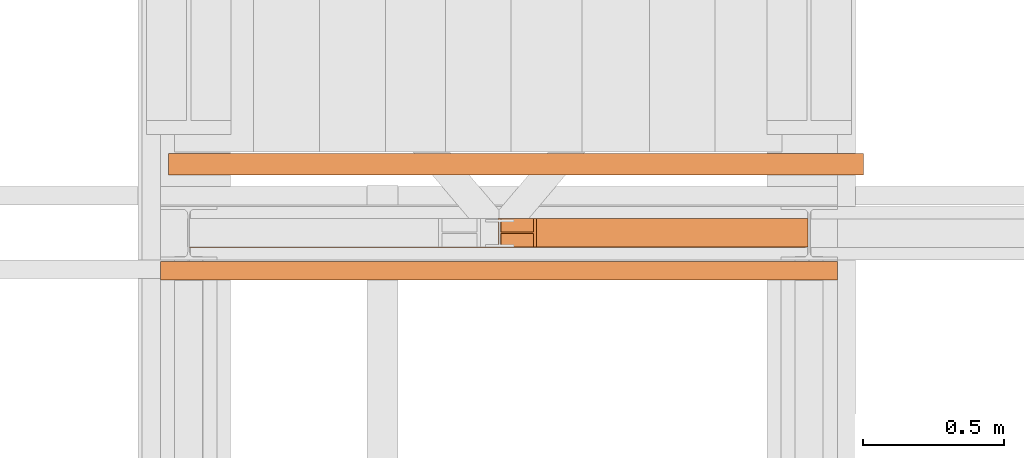
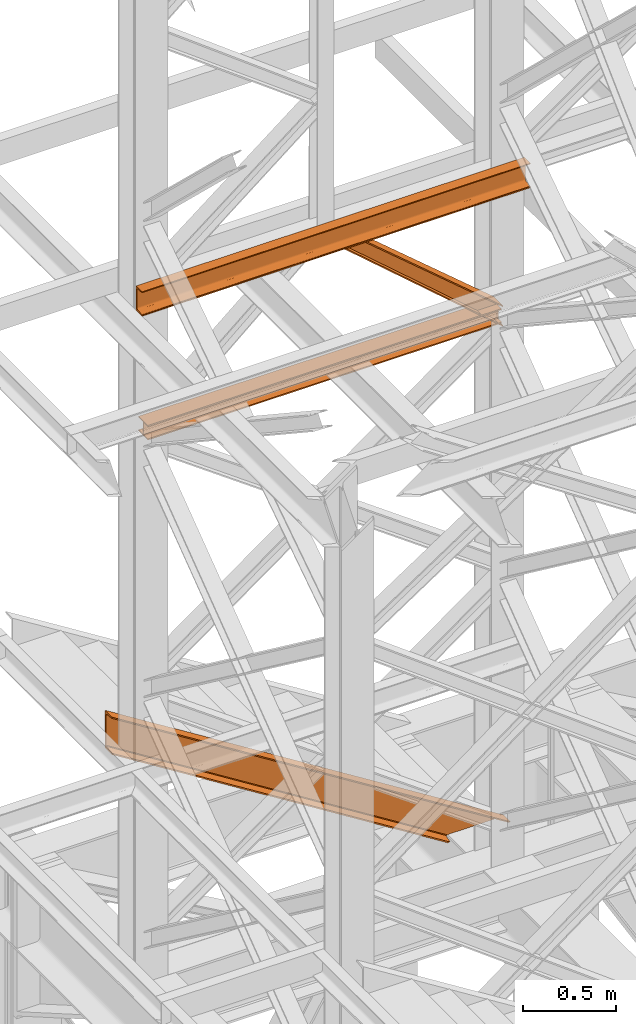
# One storey, part 103 of 208: 4 proxies.
"""IFC2X3 building model written with IfcOpenShell, lengths in millimetres."""

from ifc_helpers import new_model, entity, si_unit, converted_unit, frame, origin, origin_with_axes, place, context, subcontext, project, spatial, faceted_brep, element, save


model = new_model("IFC2X3")

# Units and contexts
model_context = context("Model", 3, precision=1e-05, world=origin())
plan_context = context("Plan", 3, precision=1e-05, world=origin())
body_context = subcontext(model_context, "Body", "Model", "MODEL_VIEW")
ifc_project = project(units=[si_unit("LENGTHUNIT", "METRE", prefix="MILLI"), converted_unit("PLANEANGLEUNIT", "DEGREE", entity("IfcPlaneAngleMeasure", 0.0174532925199433), si_unit("PLANEANGLEUNIT", "RADIAN"), dimensions=[0, 0, 0, 0, 0, 0, 0]), si_unit("AREAUNIT", "SQUARE_METRE"), si_unit("VOLUMEUNIT", "CUBIC_METRE")], contexts=[model_context, plan_context])

# Building, storey
building_placement = place(None, origin())
building = spatial("IfcBuilding", under=ifc_project, at=building_placement, CompositionType="COMPLEX")
storey_placement = place(building_placement, origin_with_axes())
storey = spatial("IfcBuildingStorey", under=building, at=storey_placement, Name="Geschoss", CompositionType="ELEMENT")

# Proxies
proxy_1_placement = place(storey_placement, frame((-3305.13110838522, -13812.57439031789, 8784.558696304413), z_axis=(0.0, 0.0, 1.0), x_axis=(1.0, 0.0, 0.0)))
element("IfcBuildingElementProxy", 1, at=proxy_1_placement, inside=storey, context=body_context, shape_type="Brep", body=[
    faceted_brep([(0.01330124084415729, 0.01000000000021828, 8.91157471702536), (0.01000000000021828, 0.01000000000021828, 0.9115753981623129), (0.01000000000021828, 100.0100000000002, 0.9115753981623129), (0.01330124084415729, 100.0100000000002, 8.91157471702536), (0.01330124084415729, 52.51000000000022, 8.91157471702536), (0.04631364927081449, 52.51000000000022, 88.91156790565765), (0.04631364927081449, 100.0100000000002, 88.91156790565765), (0.04961489011293452, 100.0100000000002, 96.91156722451888), (0.04961489011293452, 0.01000000000021828, 96.91156722451888), (0.04631364927081449, 0.01000000000021828, 88.91156790565765), (0.04631364927081449, 47.51000000000022, 88.91156790565765), (0.01330124084415729, 47.51000000000022, 8.91157471702536), (0.01000000000021828, 0.01000000000021828, 0.9115753981623129), (0.01330124084415729, 0.01000000000021828, 8.91157471702536), (2184.828925096717, 0.01000000000385626, 8.009999318863265), (2184.825623855875, 0.01000000000385626, 0.01000000000203727), (0.01000000000021828, 100.0100000000002, 0.9115753981623129), (0.01000000000021828, 0.01000000000021828, 0.9115753981623129), (2184.825623855875, 0.01000000000385626, 0.01000000000203727), (2184.825623855875, 100.0100000000039, 0.01000000000021828), (0.01330124084415729, 100.0100000000002, 8.91157471702536), (0.01000000000021828, 100.0100000000002, 0.9115753981623129), (2184.825623855875, 100.0100000000039, 0.01000000000021828), (2184.828925096717, 100.0100000000039, 8.009999318863265), (0.01330124084415729, 52.51000000000022, 8.91157471702536), (0.01330124084415729, 100.0100000000002, 8.91157471702536), (2184.828925096717, 100.0100000000039, 8.009999318863265), (2184.828925096717, 52.51000000000386, 8.009999318863265), (0.04631364927081449, 52.51000000000022, 88.91156790565765), (0.01330124084415729, 52.51000000000022, 8.91157471702536), (2184.828925096717, 52.51000000000386, 8.009999318863265), (2184.861937505144, 52.51000000000386, 88.00999250749555), (0.04631364927081449, 100.0100000000002, 88.91156790565765), (0.04631364927081449, 52.51000000000022, 88.91156790565765), (2184.861937505144, 52.51000000000386, 88.00999250749555), (2184.861937505144, 100.0100000000039, 88.00999250749555), (0.04961489011293452, 100.0100000000002, 96.91156722451888), (0.04631364927081449, 100.0100000000002, 88.91156790565765), (2184.861937505144, 100.0100000000039, 88.00999250749555), (2184.865238745986, 100.0100000000039, 96.00999182635678), (0.04961489011293452, 0.01000000000021828, 96.91156722451888), (0.04961489011293452, 100.0100000000002, 96.91156722451888), (2184.865238745986, 100.0100000000039, 96.00999182635678), (2184.865238745986, 0.01000000000385626, 96.00999182635678), (0.04631364927081449, 0.01000000000021828, 88.91156790565765), (0.04961489011293452, 0.01000000000021828, 96.91156722451888), (2184.865238745986, 0.01000000000385626, 96.00999182635678), (2184.861937505144, 0.01000000000385626, 88.00999250749373), (0.04631364927081449, 47.51000000000022, 88.91156790565765), (0.04631364927081449, 0.01000000000021828, 88.91156790565765), (2184.861937505144, 0.01000000000385626, 88.00999250749373), (2184.861937505144, 47.51000000000386, 88.00999250749555), (0.01330124084415729, 47.51000000000022, 8.91157471702536), (0.04631364927081449, 47.51000000000022, 88.91156790565765), (2184.861937505144, 47.51000000000386, 88.00999250749555), (2184.828925096717, 47.51000000000386, 8.009999318863265), (0.01330124084415729, 0.01000000000021828, 8.91157471702536), (0.01330124084415729, 47.51000000000022, 8.91157471702536), (2184.828925096717, 47.51000000000386, 8.009999318863265), (2184.828925096717, 0.01000000000385626, 8.009999318863265), (2184.828925096717, 0.01000000000385626, 8.009999318863265), (2184.828925096717, 47.51000000000386, 8.009999318863265), (2184.861937505144, 47.51000000000386, 88.00999250749555), (2184.861937505144, 0.01000000000385626, 88.00999250749373), (2184.865238745986, 0.01000000000385626, 96.00999182635678), (2184.865238745986, 100.0100000000039, 96.00999182635678), (2184.861937505144, 100.0100000000039, 88.00999250749555), (2184.861937505144, 52.51000000000386, 88.00999250749555), (2184.828925096717, 52.51000000000386, 8.009999318863265), (2184.828925096717, 100.0100000000039, 8.009999318863265), (2184.825623855875, 100.0100000000039, 0.01000000000021828), (2184.825623855875, 0.01000000000385626, 0.01000000000203727)], [[[0, 1, 2, 3, 4, 5, 6, 7, 8, 9, 10, 11]], [[12, 13, 14, 15]], [[16, 17, 18, 19]], [[20, 21, 22, 23]], [[24, 25, 26, 27]], [[28, 29, 30, 31]], [[32, 33, 34, 35]], [[36, 37, 38, 39]], [[40, 41, 42, 43]], [[44, 45, 46, 47]], [[48, 49, 50, 51]], [[52, 53, 54, 55]], [[56, 57, 58, 59]], [[60, 61, 62, 63, 64, 65, 66, 67, 68, 69, 70, 71]]], orient=[[False], [False], [False], [False], [False], [False], [False], [False], [False], [False], [False], [False], [False], [False]]),
])
proxy_2_placement = place(storey_placement, frame((-2209.780564054216, -13810.57439404318, 8758.545130132863), z_axis=(0.0, 0.0, 1.0), x_axis=(1.0, 0.0, 0.0)))
element("IfcBuildingElementProxy", 2, at=proxy_2_placement, inside=storey, context=body_context, shape_type="Brep", body=[
    faceted_brep([(1098.951267844361, 0.01000000000021828, 127.7973111790088), (125.4343327874522, 0.01000000000021828, 951.519819899715), (136.6429730091495, 0.01000000000021828, 951.5151945967082), (1098.954719807383, 0.01000000000021828, 136.1625602273089), (1098.954719807383, 0.01000000000021828, 136.1625602273089), (136.6429730091495, 0.01000000000021828, 951.5151945967082), (136.6429730091495, 100.0100000000002, 951.5151945967082), (1098.954719807383, 100.0100000000002, 136.1625602273089), (1098.954719807383, 100.0100000000002, 136.1625602273089), (136.6429730091495, 100.0100000000002, 951.5151945967082), (125.4343327874522, 100.0100000000002, 951.519819899715), (1098.951267844361, 100.0100000000002, 127.7973111790088), (1098.951267844361, 100.0100000000002, 127.7973111790088), (125.4343327874522, 100.0100000000002, 951.519819899715), (125.4343327874522, 52.51000000000022, 951.5198198997132), (1098.951267844361, 52.51000000000022, 127.7973111790088), (1098.951267844361, 52.51000000000022, 127.7973111790088), (125.4343327874522, 52.51000000000022, 951.5198198997132), (11.14167522408934, 52.51000000000022, 951.5669833523752), (1098.90198708786, 52.51000000000022, 8.373725554703924), (1098.90198708786, 52.51000000000022, 8.373725554703924), (11.14167522408934, 52.51000000000022, 951.5669833523752), (11.14167522408934, 100.0100000000002, 951.5669833523752), (1098.90198708786, 100.0100000000002, 8.373725554707562), (1098.90198708786, 100.0100000000002, 8.373725554707562), (11.14167522408934, 100.0100000000002, 951.5669833523752), (0.01000000000021828, 100.0100000000002, 951.5715768953814), (1098.898535753517, 100.0100000000002, 0.01000000000203727), (1098.898535753517, 100.0100000000002, 0.01000000000203727), (0.01000000000021828, 100.0100000000002, 951.5715768953814), (0.01000000000021828, 0.01000000000021828, 951.5715768953814), (1098.898535753517, 0.01000000000021828, 0.01000000000021828), (1098.898535753517, 0.01000000000021828, 0.01000000000021828), (0.01000000000021828, 0.01000000000021828, 951.5715768953814), (11.14167522408934, 0.01000000000021828, 951.5669833523752), (1098.90198708786, 0.01000000000021828, 8.373725554707562), (1098.90198708786, 0.01000000000021828, 8.373725554707562), (11.14167522408934, 0.01000000000021828, 951.5669833523752), (11.14167522409116, 47.51000000000022, 951.5669833523752), (1098.90198708786, 47.51000000000022, 8.3737255547112), (1098.90198708786, 47.51000000000022, 8.3737255547112), (11.14167522409116, 47.51000000000022, 951.5669833523752), (125.4343327874522, 47.51000000000022, 951.519819899715), (1098.951267844361, 47.51000000000022, 127.7973111790088), (1098.951267844361, 47.51000000000022, 127.7973111790088), (125.4343327874522, 47.51000000000022, 951.519819899715), (125.4343327874522, 0.01000000000021828, 951.519819899715), (1098.951267844361, 0.01000000000021828, 127.7973111790088), (125.4343327874522, 0.01000000000021828, 951.519819899715), (125.4343327874522, 47.51000000000022, 951.519819899715), (11.14167522409116, 47.51000000000022, 951.5669833523752), (11.14167522408934, 0.01000000000021828, 951.5669833523752), (0.01000000000021828, 0.01000000000021828, 951.5715768953814), (0.01000000000021828, 100.0100000000002, 951.5715768953814), (11.14167522408934, 100.0100000000002, 951.5669833523752), (11.14167522408934, 52.51000000000022, 951.5669833523752), (125.4343327874522, 52.51000000000022, 951.5198198997132), (125.4343327874522, 100.0100000000002, 951.519819899715), (136.6429730091495, 100.0100000000002, 951.5151945967082), (136.6429730091495, 0.01000000000021828, 951.5151945967082), (1098.954719807383, 0.01000000000021828, 136.1625602273089), (1098.954719807383, 100.0100000000002, 136.1625602273089), (1098.951267844361, 100.0100000000002, 127.7973111790088), (1098.951267844361, 52.51000000000022, 127.7973111790088), (1098.90198708786, 52.51000000000022, 8.373725554703924), (1098.90198708786, 100.0100000000002, 8.373725554707562), (1098.898535753517, 100.0100000000002, 0.01000000000203727), (1098.898535753517, 0.01000000000021828, 0.01000000000021828), (1098.90198708786, 0.01000000000021828, 8.373725554707562), (1098.90198708786, 47.51000000000022, 8.3737255547112), (1098.951267844361, 47.51000000000022, 127.7973111790088), (1098.951267844361, 0.01000000000021828, 127.7973111790088)], [[[0, 1, 2, 3]], [[4, 5, 6, 7]], [[8, 9, 10, 11]], [[12, 13, 14, 15]], [[16, 17, 18, 19]], [[20, 21, 22, 23]], [[24, 25, 26, 27]], [[28, 29, 30, 31]], [[32, 33, 34, 35]], [[36, 37, 38, 39]], [[40, 41, 42, 43]], [[44, 45, 46, 47]], [[48, 49, 50, 51, 52, 53, 54, 55, 56, 57, 58, 59]], [[60, 61, 62, 63, 64, 65, 66, 67, 68, 69, 70, 71]]], orient=[[False], [False], [False], [False], [False], [False], [False], [False], [False], [False], [False], [False], [False], [False]]),
])
proxy_3_placement = place(storey_placement, frame((-3377.982231929545, -13555.63503277033, 5299.235995667717), z_axis=(0.0, 0.0, 1.0), x_axis=(1.0, 0.0, 0.0)))
element("IfcBuildingElementProxy", 3, at=proxy_3_placement, inside=storey, context=body_context, shape_type="Brep", body=[
    faceted_brep([(0.01000000000021828, 75.01000111758731, 1546.59864079531), (0.01000000000021828, 75.01000111758731, 1301.035254730738), (2072.585730200911, 75.01000111758731, 0.01000000000021828), (2463.776225798724, 75.01000111758731, 0.01000000000021828), (0.01000000000021828, 0.01000000000021828, 1546.59864079531), (0.01000000000021828, 75.01000111758731, 1546.59864079531), (2463.776225798724, 75.01000111758731, 0.01000000000021828), (2463.776225798724, 0.01000000000021828, 0.01000000000021828), (0.01000000000021828, 0.01000000000021828, 1542.963282509618), (0.01000000000021828, 0.01000000000021828, 1546.59864079531), (2463.776225798724, 0.01000000000021828, 0.01000000000021828), (2457.984981296655, 0.01000000000021828, 0.01000000000021828), (0.01000000000021828, 1.126000115871648, 1537.563339776265), (0.01000000000021828, 0.01000000000021828, 1542.963282509618), (2457.984981296655, 0.01000000000021828, 0.01000000000021828), (2449.382696127383, 1.126000115871648, 0.01000000000021828), (0.01000000000021828, 5.531528422832707, 1535.619839744779), (0.01000000000021828, 1.126000115871648, 1537.563339776265), (2449.382696127383, 1.126000115871648, 0.01000000000021828), (2446.28663709067, 5.531528422832707, 0.01000000000112777), (0.01000000000021828, 55.92706931591056, 1530.669719952837), (0.01000000000021828, 5.531528422832707, 1535.619839744779), (2446.28663709067, 5.531528422832707, 0.01000000000112777), (2438.400934561022, 55.92706931591056, 0.01000000000112777), (0.01000000000021828, 61.66620032697938, 1528.711080065987), (0.01000000000021828, 55.92706931591056, 1530.669719952837), (2438.400934561022, 55.92706931591056, 0.01000000000112777), (2435.280757240153, 61.66620032697938, 0.009999999999308784), (0.01000000000021828, 65.51985109061025, 1523.455656628748), (0.01000000000021828, 61.66620032697938, 1528.711080065987), (2435.280757240153, 61.66620032697938, 0.009999999999308784), (2426.908696030465, 65.51985109061025, 0.01000000000021828), (0.01000000000021828, 66.51000065565131, 1516.594795610194), (0.01000000000021828, 65.51985109061025, 1523.455656628748), (2426.908696030465, 65.51985109061025, 0.01000000000021828), (2415.979120310367, 66.51000065565131, 0.01000000000112777), (0.01000000000021828, 66.51000065565131, 1331.039099915855), (0.01000000000021828, 66.51000065565131, 1516.594795610194), (2415.979120310367, 66.51000065565131, 0.01000000000112777), (2120.382835689267, 66.51000065565131, 0.01000000000021828), (0.01000000000021828, 65.51985109061025, 1324.178238897299), (0.01000000000021828, 66.51000065565131, 1331.039099915855), (2120.382835689267, 66.51000065565131, 0.01000000000021828), (2109.453259969165, 65.51985109061025, 0.01000000000021828), (0.01000000000021828, 61.66620032697938, 1318.922815460059), (0.01000000000021828, 65.51985109061025, 1324.178238897299), (2109.453259969165, 65.51985109061025, 0.01000000000021828), (2101.081198759479, 61.66620032697938, 0.01000000000021828), (0.01000000000021828, 55.92706931591056, 1316.964175573208), (0.01000000000021828, 61.66620032697938, 1318.922815460059), (2101.081198759479, 61.66620032697938, 0.01000000000021828), (2097.961021438609, 55.92706931591056, 0.01000000000203727), (0.01000000000021828, 5.531528422832707, 1312.01405578127), (0.01000000000021828, 55.92706931591056, 1316.964175573208), (2097.961021438609, 55.92706931591056, 0.01000000000203727), (2090.075318908965, 5.531528422832707, 0.01000000000021828), (0.01000000000021828, 1.126000115871648, 1310.070555749782), (0.01000000000021828, 5.531528422832707, 1312.01405578127), (2090.075318908965, 5.531528422832707, 0.01000000000021828), (2086.979259872248, 1.126000115871648, 0.01000000000385626), (0.01000000000021828, 0.01000000000021828, 1304.670613016431), (0.01000000000021828, 1.126000115871648, 1310.070555749782), (2086.979259872248, 1.126000115871648, 0.01000000000385626), (2078.37697470298, 0.01000000000021828, 0.01000000000021828), (0.01000000000021828, 0.01000000000021828, 1301.035254730738), (0.01000000000021828, 0.01000000000021828, 1304.670613016431), (2078.37697470298, 0.01000000000021828, 0.01000000000021828), (2072.585730200911, 0.01000000000021828, 0.01000000000021828), (0.01000000000021828, 75.01000111758731, 1301.035254730738), (0.01000000000021828, 0.01000000000021828, 1301.035254730738), (2072.585730200911, 0.01000000000021828, 0.01000000000021828), (2072.585730200911, 75.01000111758731, 0.01000000000021828), (0.01000000000021828, 75.01000111758731, 1546.59864079531), (0.01000000000021828, 0.01000000000021828, 1546.59864079531), (0.01000000000021828, 0.01000000000021828, 1542.963282509618), (0.01000000000021828, 1.126000115871648, 1537.563339776265), (0.01000000000021828, 5.531528422832707, 1535.619839744779), (0.01000000000021828, 55.92706931591056, 1530.669719952837), (0.01000000000021828, 61.66620032697938, 1528.711080065987), (0.01000000000021828, 65.51985109061025, 1523.455656628748), (0.01000000000021828, 66.51000065565131, 1516.594795610194), (0.01000000000021828, 66.51000065565131, 1331.039099915855), (0.01000000000021828, 65.51985109061025, 1324.178238897299), (0.01000000000021828, 61.66620032697938, 1318.922815460059), (0.01000000000021828, 55.92706931591056, 1316.964175573208), (0.01000000000021828, 5.531528422832707, 1312.01405578127), (0.01000000000021828, 1.126000115871648, 1310.070555749782), (0.01000000000021828, 0.01000000000021828, 1304.670613016431), (0.01000000000021828, 0.01000000000021828, 1301.035254730738), (0.01000000000021828, 75.01000111758731, 1301.035254730738), (2463.776225798724, 75.01000111758731, 0.01000000000021828), (2072.585730200911, 75.01000111758731, 0.01000000000021828), (2072.585730200911, 0.01000000000021828, 0.01000000000021828), (2078.37697470298, 0.01000000000021828, 0.01000000000021828), (2086.979259872248, 1.126000115871648, 0.01000000000385626), (2090.075318908965, 5.531528422832707, 0.01000000000021828), (2097.961021438609, 55.92706931591056, 0.01000000000203727), (2101.081198759479, 61.66620032697938, 0.01000000000021828), (2109.453259969165, 65.51985109061025, 0.01000000000021828), (2120.382835689267, 66.51000065565131, 0.01000000000021828), (2415.979120310367, 66.51000065565131, 0.01000000000112777), (2426.908696030465, 65.51985109061025, 0.01000000000021828), (2435.280757240153, 61.66620032697938, 0.009999999999308784), (2438.400934561022, 55.92706931591056, 0.01000000000112777), (2446.28663709067, 5.531528422832707, 0.01000000000112777), (2449.382696127383, 1.126000115871648, 0.01000000000021828), (2457.984981296655, 0.01000000000021828, 0.01000000000021828), (2463.776225798724, 0.01000000000021828, 0.01000000000021828)], [[[0, 1, 2, 3]], [[4, 5, 6, 7]], [[8, 9, 10, 11]], [[12, 13, 14, 15]], [[16, 17, 18, 19]], [[20, 21, 22, 23]], [[24, 25, 26, 27]], [[28, 29, 30, 31]], [[32, 33, 34, 35]], [[36, 37, 38, 39]], [[40, 41, 42, 43]], [[44, 45, 46, 47]], [[48, 49, 50, 51]], [[52, 53, 54, 55]], [[56, 57, 58, 59]], [[60, 61, 62, 63]], [[64, 65, 66, 67]], [[68, 69, 70, 71]], [[72, 73, 74, 75, 76, 77, 78, 79, 80, 81, 82, 83, 84, 85, 86, 87, 88, 89]], [[90, 91, 92, 93, 94, 95, 96, 97, 98, 99, 100, 101, 102, 103, 104, 105, 106, 107]]], orient=[[False], [False], [False], [False], [False], [False], [False], [False], [False], [False], [False], [False], [False], [False], [False], [False], [False], [False], [False], [False]]),
])
proxy_4_placement = place(storey_placement, frame((-3406.417384675593, -13927.76858191269, 9699.99), z_axis=(0.0, 0.0, 1.0), x_axis=(1.0, 0.0, 0.0)))
element("IfcBuildingElementProxy", 4, at=proxy_4_placement, inside=storey, context=body_context, shape_type="Brep", body=[
    faceted_brep([(0.01000000000021828, 0.00999999999839929, 0.01000000000021828), (0.01000000000021828, 0.00999999999839929, 3.132428070246533), (2399.682354694371, 0.2527365771729819, 3.132428070246533), (2399.682354694371, 0.2527365771729819, 0.01000000000021828), (0.01000000000021828, 0.00999999999839929, 3.132428070246533), (0.01000000000021828, 0.2527365771729819, 4.748288908171162), (2399.682354694371, 0.4954731543457456, 4.748288908171162), (2399.682354694371, 0.2527365771729819, 3.132428070246533), (0.01000000000021828, 0.2527365771729819, 4.748288908171162), (0.01000000000021828, 0.9594677141431021, 6.221534443444398), (2399.682354694371, 1.202204291315866, 6.221534443444398), (2399.682354694371, 0.4954731543457456, 4.748288908171162), (0.01000000000021828, 0.9594677141431021, 6.221534443444398), (0.01000000000021828, 2.067848361530196, 7.422126703873801), (2399.682354694371, 2.310584938702959, 7.422126703873801), (2399.682354694371, 1.202204291315866, 6.221534443444398), (0.01000000000021828, 2.067848361530196, 7.422126703873801), (0.01000000000021828, 3.480043588513581, 8.244091391710754), (2399.682354694371, 3.722780165688164, 8.244091391710754), (2399.682354694371, 2.310584938702959, 7.422126703873801), (0.01000000000021828, 3.480043588513581, 8.244091391710754), (0.01000000000021828, 5.071401277442419, 8.614912102195376), (2399.682354694371, 5.314137854617002, 8.614912102195376), (2399.682354694371, 3.722780165688164, 8.244091391710754), (0.01000000000021828, 5.071401277442419, 8.614912102195376), (0.01000000000021828, 47.84732483396874, 12.0369859867169), (2399.682354694371, 48.09006141114332, 12.0369859867169), (2399.682354694371, 5.314137854617002, 8.614912102195376), (0.01000000000021828, 47.84732483396874, 12.0369859867169), (0.01000000000021828, 50.88537133101454, 12.74491643400506), (2399.682354694371, 51.12810790818912, 12.74491643400506), (2399.682354694371, 48.09006141114332, 12.0369859867169), (0.01000000000021828, 50.88537133101454, 12.74491643400506), (0.01000000000021828, 53.58138040071208, 14.31412174714933), (2399.682354694371, 53.82411697788666, 14.31412174714933), (2399.682354694371, 51.12810790818912, 12.74491643400506), (0.01000000000021828, 53.58138040071208, 14.31412174714933), (0.01000000000021828, 55.69737981845174, 16.60616151705835), (2399.682354694371, 55.94011639562632, 16.60616151705835), (2399.682354694371, 53.82411697788666, 14.31412174714933), (0.01000000000021828, 55.69737981845174, 16.60616151705835), (0.01000000000021828, 57.04659380721387, 19.41872117530875), (2399.682354694371, 57.28933038438663, 19.41872117530875), (2399.682354694371, 55.94011639562632, 16.60616151705835), (0.01000000000021828, 57.04659380721387, 19.41872117530875), (0.01000000000021828, 57.5099999999984, 22.50354641134618), (2399.682354694371, 57.75273657717298, 22.50354641134618), (2399.682354694371, 57.28933038438663, 19.41872117530875), (0.01000000000021828, 57.5099999999984, 22.50354641134618), (0.01000000000021828, 57.5099999999984, 137.5164535886524), (2399.682354694371, 57.75273657717298, 137.5164535886524), (2399.682354694371, 57.75273657717298, 22.50354641134618), (0.01000000000021828, 57.5099999999984, 137.5164535886524), (0.01000000000021828, 57.04659380721387, 140.6012788246917), (2399.682354694371, 57.28933038438663, 140.6012788246917), (2399.682354694371, 57.75273657717298, 137.5164535886524), (0.01000000000021828, 57.04659380721387, 140.6012788246917), (0.01000000000021828, 55.69737981845174, 143.4138384829403), (2399.682354694371, 55.94011639562632, 143.4138384829403), (2399.682354694371, 57.28933038438663, 140.6012788246917), (0.01000000000021828, 55.69737981845174, 143.4138384829403), (0.01000000000021828, 53.58138040071208, 145.7058782528493), (2399.682354694371, 53.82411697788666, 145.7058782528493), (2399.682354694371, 55.94011639562632, 143.4138384829403), (0.01000000000021828, 53.58138040071208, 145.7058782528493), (0.01000000000021828, 50.88537133101454, 147.2750835659936), (2399.682354694371, 51.12810790818912, 147.2750835659936), (2399.682354694371, 53.82411697788666, 145.7058782528493), (0.01000000000021828, 50.88537133101454, 147.2750835659936), (0.01000000000021828, 47.84732483396874, 147.9830140132817), (2399.682354694371, 48.09006141114332, 147.9830140132817), (2399.682354694371, 51.12810790818912, 147.2750835659936), (0.01000000000021828, 47.84732483396874, 147.9830140132817), (0.01000000000021828, 5.071401277442419, 151.4050878978032), (2399.682354694371, 5.314137854617002, 151.4050878978032), (2399.682354694371, 48.09006141114332, 147.9830140132817), (0.01000000000021828, 5.071401277442419, 151.4050878978032), (0.01000000000021828, 3.480043588513581, 151.7759086082879), (2399.682354694371, 3.722780165688164, 151.7759086082879), (2399.682354694371, 5.314137854617002, 151.4050878978032), (0.01000000000021828, 3.480043588513581, 151.7759086082879), (0.01000000000021828, 2.067848361530196, 152.5978732961248), (2399.682354694371, 2.310584938702959, 152.5978732961248), (2399.682354694371, 3.722780165688164, 151.7759086082879), (0.01000000000021828, 2.067848361530196, 152.5978732961248), (0.01000000000021828, 0.9594677141431021, 153.7984655565542), (2399.682354694371, 1.202204291315866, 153.7984655565542), (2399.682354694371, 2.310584938702959, 152.5978732961248), (0.01000000000021828, 0.9594677141431021, 153.7984655565542), (0.01000000000021828, 0.2527365771729819, 155.2717110918275), (2399.682354694371, 0.4954731543457456, 155.2717110918275), (2399.682354694371, 1.202204291315866, 153.7984655565542), (0.01000000000021828, 0.2527365771729819, 155.2717110918275), (0.01000000000021828, 0.00999999999839929, 156.8875719297521), (2399.682354694371, 0.2527365771729819, 156.8875719297521), (2399.682354694371, 0.4954731543457456, 155.2717110918275), (0.01000000000021828, 0.00999999999839929, 156.8875719297521), (0.01000000000021828, 0.00999999999839929, 160.0100000000002), (2399.682354694371, 0.2527365771729819, 160.0100000000002), (2399.682354694371, 0.2527365771729819, 156.8875719297521), (0.01000000000021828, 0.00999999999839929, 160.0100000000002), (0.01000000000021828, 65.0099999999984, 160.0100000000002), (2399.682354694371, 65.25273657717298, 160.0100000000002), (2399.682354694371, 0.2527365771729819, 160.0100000000002), (0.01000000000021828, 65.0099999999984, 160.0100000000002), (0.01000000000021828, 65.0099999999984, 0.01000000000021828), (2399.682354694371, 65.25273657717298, 0.01000000000021828), (2399.682354694371, 65.25273657717298, 160.0100000000002), (0.01000000000021828, 65.0099999999984, 0.01000000000021828), (0.01000000000021828, 0.00999999999839929, 0.01000000000021828), (2399.682354694371, 0.2527365771729819, 0.01000000000021828), (2399.682354694371, 65.25273657717298, 0.01000000000021828), (0.01000000000021828, 0.00999999999839929, 0.01000000000021828), (0.01000000000021828, 65.0099999999984, 0.01000000000021828), (0.01000000000021828, 65.0099999999984, 160.0100000000002), (0.01000000000021828, 0.00999999999839929, 160.0100000000002), (0.01000000000021828, 0.00999999999839929, 156.8875719297521), (0.01000000000021828, 0.2527365771729819, 155.2717110918275), (0.01000000000021828, 0.9594677141431021, 153.7984655565542), (0.01000000000021828, 2.067848361530196, 152.5978732961248), (0.01000000000021828, 3.480043588513581, 151.7759086082879), (0.01000000000021828, 5.071401277442419, 151.4050878978032), (0.01000000000021828, 47.84732483396874, 147.9830140132817), (0.01000000000021828, 50.88537133101454, 147.2750835659936), (0.01000000000021828, 53.58138040071208, 145.7058782528493), (0.01000000000021828, 55.69737981845174, 143.4138384829403), (0.01000000000021828, 57.04659380721387, 140.6012788246917), (0.01000000000021828, 57.5099999999984, 137.5164535886524), (0.01000000000021828, 57.5099999999984, 22.50354641134618), (0.01000000000021828, 57.04659380721387, 19.41872117530875), (0.01000000000021828, 55.69737981845174, 16.60616151705835), (0.01000000000021828, 53.58138040071208, 14.31412174714933), (0.01000000000021828, 50.88537133101454, 12.74491643400506), (0.01000000000021828, 47.84732483396874, 12.0369859867169), (0.01000000000021828, 5.071401277442419, 8.614912102195376), (0.01000000000021828, 3.480043588513581, 8.244091391710754), (0.01000000000021828, 2.067848361530196, 7.422126703873801), (0.01000000000021828, 0.9594677141431021, 6.221534443444398), (0.01000000000021828, 0.2527365771729819, 4.748288908171162), (0.01000000000021828, 0.00999999999839929, 3.132428070246533), (2399.682354694371, 0.2527365771729819, 0.01000000000021828), (2399.682354694371, 0.2527365771729819, 3.132428070246533), (2399.682354694371, 0.4954731543457456, 4.748288908171162), (2399.682354694371, 1.202204291315866, 6.221534443444398), (2399.682354694371, 2.310584938702959, 7.422126703873801), (2399.682354694371, 3.722780165688164, 8.244091391710754), (2399.682354694371, 5.314137854617002, 8.614912102195376), (2399.682354694371, 48.09006141114332, 12.0369859867169), (2399.682354694371, 51.12810790818912, 12.74491643400506), (2399.682354694371, 53.82411697788666, 14.31412174714933), (2399.682354694371, 55.94011639562632, 16.60616151705835), (2399.682354694371, 57.28933038438663, 19.41872117530875), (2399.682354694371, 57.75273657717298, 22.50354641134618), (2399.682354694371, 57.75273657717298, 137.5164535886524), (2399.682354694371, 57.28933038438663, 140.6012788246917), (2399.682354694371, 55.94011639562632, 143.4138384829403), (2399.682354694371, 53.82411697788666, 145.7058782528493), (2399.682354694371, 51.12810790818912, 147.2750835659936), (2399.682354694371, 48.09006141114332, 147.9830140132817), (2399.682354694371, 5.314137854617002, 151.4050878978032), (2399.682354694371, 3.722780165688164, 151.7759086082879), (2399.682354694371, 2.310584938702959, 152.5978732961248), (2399.682354694371, 1.202204291315866, 153.7984655565542), (2399.682354694371, 0.4954731543457456, 155.2717110918275), (2399.682354694371, 0.2527365771729819, 156.8875719297521), (2399.682354694371, 0.2527365771729819, 160.0100000000002), (2399.682354694371, 65.25273657717298, 160.0100000000002), (2399.682354694371, 65.25273657717298, 0.01000000000021828)], [[[0, 1, 2, 3]], [[4, 5, 6, 7]], [[8, 9, 10, 11]], [[12, 13, 14, 15]], [[16, 17, 18, 19]], [[20, 21, 22, 23]], [[24, 25, 26, 27]], [[28, 29, 30, 31]], [[32, 33, 34, 35]], [[36, 37, 38, 39]], [[40, 41, 42, 43]], [[44, 45, 46, 47]], [[48, 49, 50, 51]], [[52, 53, 54, 55]], [[56, 57, 58, 59]], [[60, 61, 62, 63]], [[64, 65, 66, 67]], [[68, 69, 70, 71]], [[72, 73, 74, 75]], [[76, 77, 78, 79]], [[80, 81, 82, 83]], [[84, 85, 86, 87]], [[88, 89, 90, 91]], [[92, 93, 94, 95]], [[96, 97, 98, 99]], [[100, 101, 102, 103]], [[104, 105, 106, 107]], [[108, 109, 110, 111]], [[112, 113, 114, 115, 116, 117, 118, 119, 120, 121, 122, 123, 124, 125, 126, 127, 128, 129, 130, 131, 132, 133, 134, 135, 136, 137, 138, 139]], [[140, 141, 142, 143, 144, 145, 146, 147, 148, 149, 150, 151, 152, 153, 154, 155, 156, 157, 158, 159, 160, 161, 162, 163, 164, 165, 166, 167]]], orient=[[False], [False], [False], [False], [False], [False], [False], [False], [False], [False], [False], [False], [False], [False], [False], [False], [False], [False], [False], [False], [False], [False], [False], [False], [False], [False], [False], [False], [False], [False]]),
])

save(model, "model.ifc")
